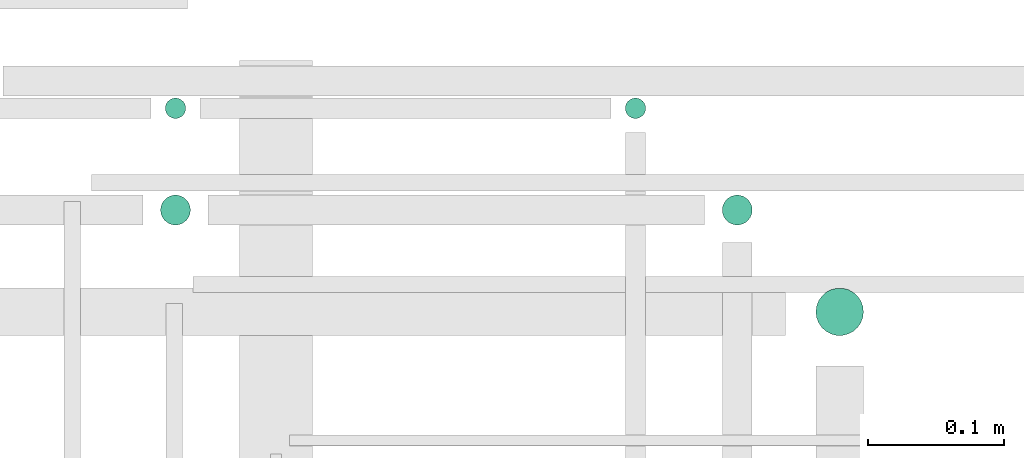
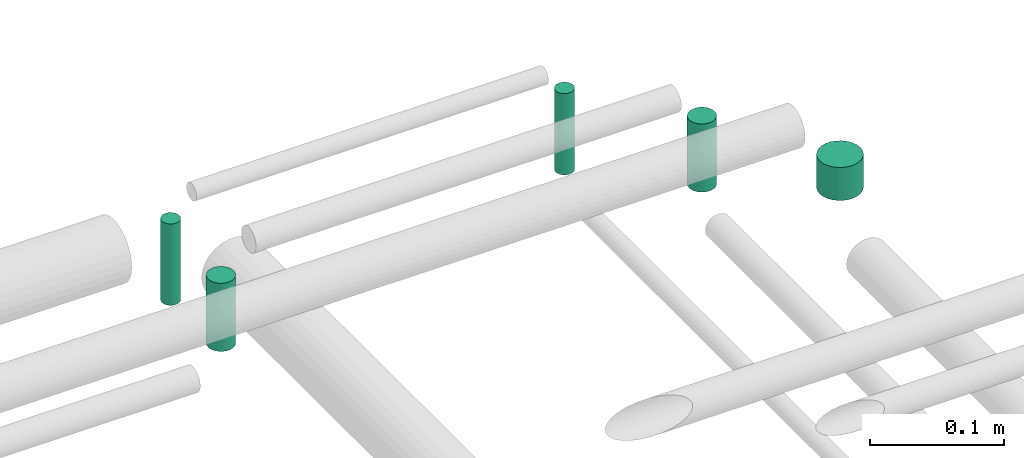
# One storey, part 310 of 331: 5 flow segments.
"""IFC2X3 building model written with IfcOpenShell, lengths in millimetres."""

from ifc_helpers import new_model, entity, si_unit, converted_unit, derived_unit, direction, frame, frame_2d, origin, origin_2d_with_axis, place, context, subcontext, project, spatial, circle, extrude, type_object, element, save


model = new_model("IFC2X3")

# Units and contexts
model_context = context("Model", 3, precision=0.01, world=origin(), true_north=direction((6.12303176911189e-17, 1.0)))
body_context = subcontext(model_context, "Body", "Model", "MODEL_VIEW")
ifc_project = project(units=[si_unit("LENGTHUNIT", "METRE", prefix="MILLI"), si_unit("AREAUNIT", "SQUARE_METRE"), si_unit("VOLUMEUNIT", "CUBIC_METRE"), converted_unit("PLANEANGLEUNIT", "DEGREE", entity("IfcRatioMeasure", 0.0174532925199433), si_unit("PLANEANGLEUNIT", "RADIAN"), dimensions=[0, 0, 0, 0, 0, 0, 0]), si_unit("MASSUNIT", "GRAM", prefix="KILO"), derived_unit("MASSDENSITYUNIT", [(si_unit("MASSUNIT", "GRAM", prefix="KILO"), 1), (si_unit("LENGTHUNIT", "METRE"), -3)]), derived_unit("MOMENTOFINERTIAUNIT", [(si_unit("LENGTHUNIT", "METRE"), 4)]), si_unit("TIMEUNIT", "SECOND"), si_unit("FREQUENCYUNIT", "HERTZ"), si_unit("THERMODYNAMICTEMPERATUREUNIT", "DEGREE_CELSIUS"), derived_unit("THERMALTRANSMITTANCEUNIT", [(si_unit("MASSUNIT", "GRAM", prefix="KILO"), 1), (si_unit("THERMODYNAMICTEMPERATUREUNIT", "KELVIN"), -1), (si_unit("TIMEUNIT", "SECOND"), -3)]), derived_unit("VOLUMETRICFLOWRATEUNIT", [(si_unit("LENGTHUNIT", "METRE"), 3), (si_unit("TIMEUNIT", "SECOND"), -1)]), derived_unit("MASSFLOWRATEUNIT", [(si_unit("MASSUNIT", "GRAM", prefix="KILO"), 1), (si_unit("TIMEUNIT", "SECOND"), -1)]), derived_unit("ROTATIONALFREQUENCYUNIT", [(si_unit("TIMEUNIT", "SECOND"), -1)]), si_unit("ELECTRICCURRENTUNIT", "AMPERE"), si_unit("ELECTRICVOLTAGEUNIT", "VOLT"), si_unit("POWERUNIT", "WATT"), si_unit("FORCEUNIT", "NEWTON", prefix="KILO"), si_unit("ILLUMINANCEUNIT", "LUX"), si_unit("LUMINOUSFLUXUNIT", "LUMEN"), si_unit("LUMINOUSINTENSITYUNIT", "CANDELA"), derived_unit("USERDEFINED", [(si_unit("MASSUNIT", "GRAM", prefix="KILO"), -1), (si_unit("LENGTHUNIT", "METRE"), -2), (si_unit("TIMEUNIT", "SECOND"), 3), (si_unit("LUMINOUSFLUXUNIT", "LUMEN"), 1)]), derived_unit("LINEARVELOCITYUNIT", [(si_unit("LENGTHUNIT", "METRE"), 1), (si_unit("TIMEUNIT", "SECOND"), -1)]), si_unit("PRESSUREUNIT", "PASCAL"), derived_unit("USERDEFINED", [(si_unit("LENGTHUNIT", "METRE"), -2), (si_unit("MASSUNIT", "GRAM", prefix="KILO"), 1), (si_unit("TIMEUNIT", "SECOND"), -2)]), derived_unit("LINEARFORCEUNIT", [(si_unit("MASSUNIT", "GRAM", prefix="KILO"), 1), (si_unit("LENGTHUNIT", "METRE"), 1), (si_unit("TIMEUNIT", "SECOND"), -2), (si_unit("LENGTHUNIT", "METRE"), -1)]), derived_unit("PLANARFORCEUNIT", [(si_unit("MASSUNIT", "GRAM", prefix="KILO"), 1), (si_unit("LENGTHUNIT", "METRE"), 1), (si_unit("TIMEUNIT", "SECOND"), -2), (si_unit("LENGTHUNIT", "METRE"), -2)])], contexts=[model_context])

# Site, building, storey
site_placement = place(None, frame((0.0, -0.00077364408347762, 0.0)))
site = spatial("IfcSite", under=ifc_project, at=site_placement, CompositionType="ELEMENT")
building_placement = place(site_placement, origin())
building = spatial("IfcBuilding", under=site, at=building_placement, CompositionType="ELEMENT")
storey_placement = place(building_placement, origin())
storey = spatial("IfcBuildingStorey", under=building, at=storey_placement, CompositionType="ELEMENT", Elevation=0.0)

# Flow segments
pipe_segment_type = type_object("IfcPipeSegmentType", PredefinedType="NOTDEFINED")
flow_segment_1_placement = place(storey_placement, frame((65481.517459311, 8840.71546224623, 18490.0)))
element("IfcFlowSegment", 1, at=flow_segment_1_placement, inside=storey, type_object=pipe_segment_type, context=body_context, shape_type="SweptSolid", body=[
    extrude(circle(Radius=17.5, at=frame_2d((-8.66293703438714e-12, 0.0), x_axis=(1.0, 0.0))), frame((19.0952722359206, 19.0952722359163, 0.0)), (0.0, 0.0, 1.0), 30.0000000000105),
])
flow_segment_2_placement = place(storey_placement, frame((65412.5166110417, 8922.21546224628, 18474.0)))
element("IfcFlowSegment", 2, at=flow_segment_2_placement, inside=storey, type_object=pipe_segment_type, context=body_context, shape_type="SweptSolid", body=[
    extrude(circle(Radius=11.0, at=origin_2d_with_axis()), frame((12.5952722359134, 12.5952722359156, 0.0), z_axis=(0.0, 0.0, 1.0), x_axis=(-1.0, 0.0, 0.0)), (0.0, 0.0, 1.0), 62.0000000000141),
])
flow_segment_3_placement = place(storey_placement, frame((65341.0166110418, 9000.71546224627, 18468.0)))
element("IfcFlowSegment", 3, at=flow_segment_3_placement, inside=storey, type_object=pipe_segment_type, context=body_context, shape_type="SweptSolid", body=[
    extrude(circle(Radius=7.5, at=origin_2d_with_axis()), frame((9.09527223591419, 9.09527223591636, 0.0)), (0.0, 0.0, 1.0), 74.0000000000243),
])
flow_segment_4_placement = place(storey_placement, frame((65002.0166110417, 9000.71546224627, 18468.0)))
element("IfcFlowSegment", 4, at=flow_segment_4_placement, inside=storey, type_object=pipe_segment_type, context=body_context, shape_type="SweptSolid", body=[
    extrude(circle(Radius=7.5, at=origin_2d_with_axis()), frame((9.09527223591419, 9.09527223591636, 0.0), z_axis=(0.0, 0.0, 1.0), x_axis=(-1.0, 0.0, 0.0)), (0.0, 0.0, 1.0), 74.0000000000395),
])
flow_segment_5_placement = place(storey_placement, frame((64998.5166110417, 8922.21546224628, 18474.0)))
element("IfcFlowSegment", 5, at=flow_segment_5_placement, inside=storey, type_object=pipe_segment_type, context=body_context, shape_type="SweptSolid", body=[
    extrude(circle(Radius=11.0, at=origin_2d_with_axis()), frame((12.5952722359134, 12.5952722359156, 0.0), z_axis=(0.0, 0.0, 1.0), x_axis=(-1.0, 0.0, 0.0)), (0.0, 0.0, 1.0), 62.0000000000119),
])

save(model, "model.ifc")
